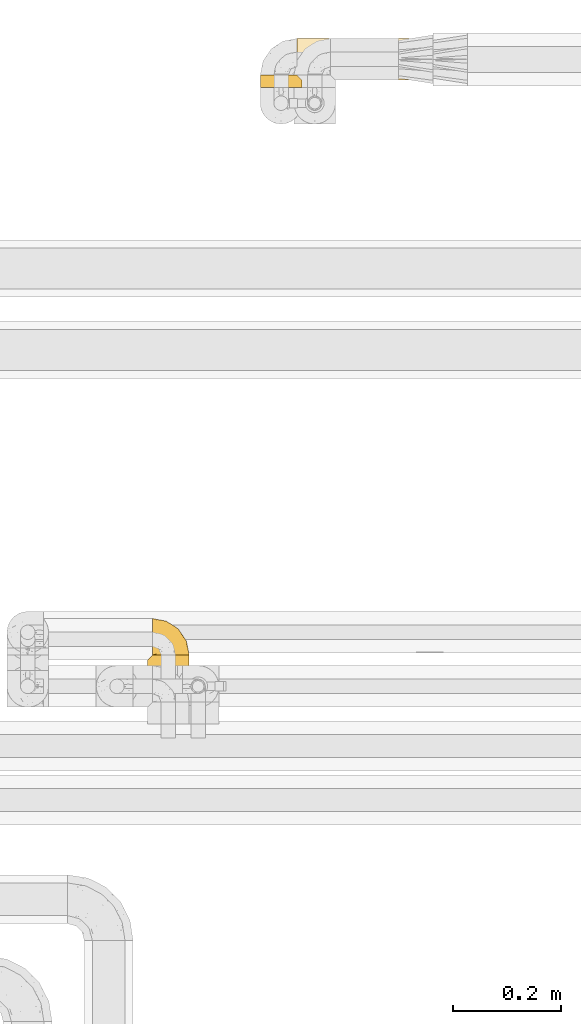
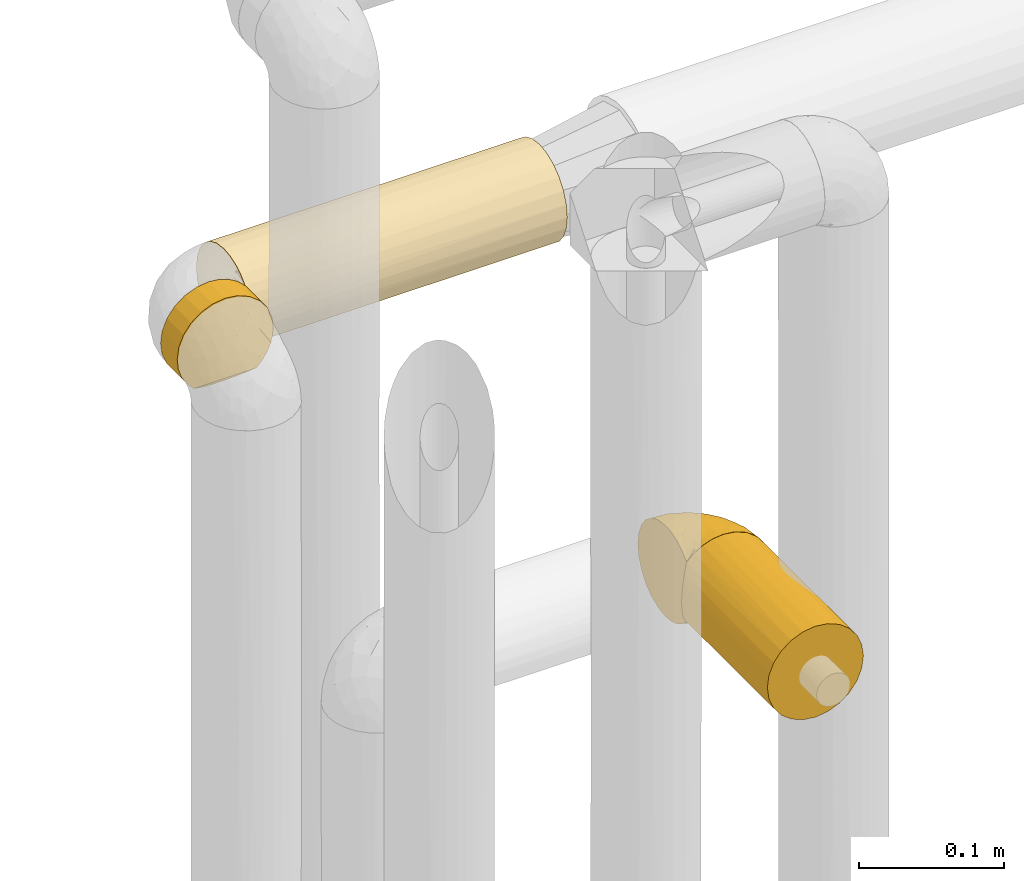
# One storey, part 332 of 827: 4 coverings.
"""IFC2X3 building model written with IfcOpenShell, lengths in millimetres."""

from ifc_helpers import new_model, entity, si_unit, converted_unit, derived_unit, direction, frame, origin, place, context, subcontext, project, spatial, faceted_brep, element, save


model = new_model("IFC2X3")

# Units and contexts
model_context = context("Model", 3, precision=0.01, world=origin(), true_north=direction((6.12303176911189e-17, 1.0)))
body_context = subcontext(model_context, "Body", "Model", "MODEL_VIEW")
ifc_project = project(units=[si_unit("LENGTHUNIT", "METRE", prefix="MILLI"), si_unit("AREAUNIT", "SQUARE_METRE"), si_unit("VOLUMEUNIT", "CUBIC_METRE"), converted_unit("PLANEANGLEUNIT", "DEGREE", entity("IfcRatioMeasure", 0.0174532925199433), si_unit("PLANEANGLEUNIT", "RADIAN"), dimensions=[0, 0, 0, 0, 0, 0, 0]), si_unit("MASSUNIT", "GRAM", prefix="KILO"), derived_unit("MASSDENSITYUNIT", [(si_unit("MASSUNIT", "GRAM", prefix="KILO"), 1), (si_unit("LENGTHUNIT", "METRE"), -3)]), derived_unit("MOMENTOFINERTIAUNIT", [(si_unit("LENGTHUNIT", "METRE"), 4)]), si_unit("TIMEUNIT", "SECOND"), si_unit("FREQUENCYUNIT", "HERTZ"), si_unit("THERMODYNAMICTEMPERATUREUNIT", "DEGREE_CELSIUS"), derived_unit("THERMALTRANSMITTANCEUNIT", [(si_unit("MASSUNIT", "GRAM", prefix="KILO"), 1), (si_unit("THERMODYNAMICTEMPERATUREUNIT", "KELVIN"), -1), (si_unit("TIMEUNIT", "SECOND"), -3)]), derived_unit("VOLUMETRICFLOWRATEUNIT", [(si_unit("LENGTHUNIT", "METRE"), 3), (si_unit("TIMEUNIT", "SECOND"), -1)]), derived_unit("MASSFLOWRATEUNIT", [(si_unit("MASSUNIT", "GRAM", prefix="KILO"), 1), (si_unit("TIMEUNIT", "SECOND"), -1)]), derived_unit("ROTATIONALFREQUENCYUNIT", [(si_unit("TIMEUNIT", "SECOND"), -1)]), si_unit("ELECTRICCURRENTUNIT", "AMPERE"), si_unit("ELECTRICVOLTAGEUNIT", "VOLT"), si_unit("POWERUNIT", "WATT"), si_unit("FORCEUNIT", "NEWTON", prefix="KILO"), si_unit("ILLUMINANCEUNIT", "LUX"), si_unit("LUMINOUSFLUXUNIT", "LUMEN"), si_unit("LUMINOUSINTENSITYUNIT", "CANDELA"), derived_unit("USERDEFINED", [(si_unit("MASSUNIT", "GRAM", prefix="KILO"), -1), (si_unit("LENGTHUNIT", "METRE"), -2), (si_unit("TIMEUNIT", "SECOND"), 3), (si_unit("LUMINOUSFLUXUNIT", "LUMEN"), 1)]), derived_unit("LINEARVELOCITYUNIT", [(si_unit("LENGTHUNIT", "METRE"), 1), (si_unit("TIMEUNIT", "SECOND"), -1)]), si_unit("PRESSUREUNIT", "PASCAL"), derived_unit("USERDEFINED", [(si_unit("LENGTHUNIT", "METRE"), -2), (si_unit("MASSUNIT", "GRAM", prefix="KILO"), 1), (si_unit("TIMEUNIT", "SECOND"), -2)]), derived_unit("LINEARFORCEUNIT", [(si_unit("MASSUNIT", "GRAM", prefix="KILO"), 1), (si_unit("LENGTHUNIT", "METRE"), 1), (si_unit("TIMEUNIT", "SECOND"), -2), (si_unit("LENGTHUNIT", "METRE"), -1)]), derived_unit("PLANARFORCEUNIT", [(si_unit("MASSUNIT", "GRAM", prefix="KILO"), 1), (si_unit("LENGTHUNIT", "METRE"), 1), (si_unit("TIMEUNIT", "SECOND"), -2), (si_unit("LENGTHUNIT", "METRE"), -2)])], contexts=[model_context])

# Site, building, storey
site_placement = place(None, origin())
site = spatial("IfcSite", under=ifc_project, at=site_placement, CompositionType="ELEMENT")
building_placement = place(site_placement, origin())
building = spatial("IfcBuilding", under=site, at=building_placement, CompositionType="ELEMENT")
storey_placement = place(building_placement, frame((0.0, 0.0, 28200.0)))
storey = spatial("IfcBuildingStorey", under=building, at=storey_placement, Name="08", CompositionType="ELEMENT", Elevation=28200.0)

# Coverings
covering_1_placement = place(storey_placement, frame((35021.28, 19454.61, 1660.0)))
element("IfcCovering", 1, at=covering_1_placement, inside=storey, Name=":ADSK_", ObjectType=":ADSK_", PredefinedType="INSULATION", context=body_context, shape_type="Brep", body=[
    faceted_brep([(253.75, 73.25, 20.8), (253.75, 77.09, 30.06), (253.75, 78.4, 40.0), (253.75, 77.09, 49.93), (253.75, 73.25, 59.2), (253.75, 67.15, 67.15), (253.75, 59.2, 73.25), (253.75, 49.93, 77.09), (253.75, 40.0, 78.4), (253.75, 30.06, 77.09), (253.75, 20.8, 73.25), (253.75, 12.84, 67.15), (253.75, 6.74, 59.2), (253.75, 2.9, 49.93), (253.75, 1.6, 40.0), (253.75, 2.9, 30.06), (253.75, 6.74, 20.8), (253.75, 12.84, 12.84), (253.75, 20.8, 6.74), (253.75, 30.06, 2.9), (253.75, 40.0, 1.6), (253.75, 49.93, 2.9), (253.75, 59.2, 6.74), (253.75, 67.15, 12.84), (1.6, 78.4, 40.0), (1.6, 77.09, 30.06), (1.6, 73.25, 20.8), (1.6, 67.15, 12.84), (1.6, 59.2, 6.74), (1.6, 49.93, 2.9), (1.6, 40.0, 1.6), (1.6, 31.79, 2.48), (1.6, 23.98, 5.09), (1.6, 16.91, 9.31), (1.6, 10.9, 14.94), (1.6, 10.9, 65.05), (1.6, 16.91, 70.68), (1.6, 23.98, 74.9), (1.6, 31.79, 77.51), (1.6, 40.0, 78.4), (1.6, 49.93, 77.09), (1.6, 59.2, 73.25), (1.6, 67.15, 67.15), (1.6, 73.25, 59.2), (1.6, 77.09, 49.93), (10.29, 2.2, 33.21), (8.5, 4.0, 26.63), (5.57, 6.92, 20.48), (10.9, 1.6, 40.0), (5.57, 6.92, 59.51), (8.5, 4.0, 53.36), (10.29, 2.2, 46.78)], [[[0, 1, 2, 3, 4, 5, 6, 7, 8, 9, 10, 11, 12, 13, 14, 15, 16, 17, 18, 19, 20, 21, 22, 23]], [[24, 25, 26, 27, 28, 29, 30, 31, 32, 33, 34, 35, 36, 37, 38, 39, 40, 41, 42, 43, 44]], [[45, 46, 15]], [[47, 34, 16]], [[46, 47, 16]], [[48, 45, 14]], [[14, 45, 15]], [[46, 16, 15]], [[34, 17, 16]], [[18, 33, 32]], [[19, 32, 31]], [[20, 31, 30]], [[17, 33, 18]], [[18, 32, 19]], [[31, 20, 19]], [[33, 17, 34]], [[21, 20, 30, 29]], [[22, 21, 29, 28]], [[28, 27, 23, 22]], [[1, 0, 26, 25]], [[2, 1, 25, 24]], [[27, 26, 0, 23]], [[3, 2, 24, 44]], [[4, 3, 44, 43]], [[43, 42, 5, 4]], [[7, 6, 41, 40]], [[8, 7, 40, 39]], [[42, 41, 6, 5]], [[8, 39, 38]], [[9, 38, 37]], [[10, 37, 36]], [[8, 38, 9]], [[9, 37, 10]], [[36, 11, 10]], [[36, 35, 11]], [[35, 49, 12]], [[50, 51, 13]], [[49, 50, 12]], [[12, 50, 13]], [[14, 13, 51]], [[48, 14, 51]], [[35, 12, 11]], [[34, 47, 46, 45, 48, 51, 50, 49, 35]]]),
])
covering_2_placement = place(storey_placement, frame((34953.78, 19440.94, 1660.0)))
element("IfcCovering", 2, at=covering_2_placement, inside=storey, Name=":ADSK_", ObjectType=":ADSK_", PredefinedType="INSULATION", context=body_context, shape_type="Brep", body=[
    faceted_brep([(20.8, 24.57, 73.25), (30.06, 24.57, 77.09), (40.0, 24.57, 78.4), (48.2, 24.57, 77.51), (56.01, 24.57, 74.9), (63.08, 24.57, 70.68), (69.1, 24.57, 65.05), (69.1, 24.57, 14.94), (63.08, 24.57, 9.31), (56.01, 24.57, 5.09), (48.2, 24.57, 2.48), (40.0, 24.57, 1.6), (30.06, 24.57, 2.9), (20.8, 24.57, 6.74), (12.84, 24.57, 12.84), (6.74, 24.57, 20.8), (2.9, 24.57, 30.06), (1.6, 24.57, 40.0), (2.9, 24.57, 49.93), (6.74, 24.57, 59.2), (12.84, 24.57, 67.15), (40.0, 1.6, 78.4), (30.06, 1.6, 77.09), (20.8, 1.6, 73.25), (12.84, 1.6, 67.15), (6.74, 1.6, 59.2), (2.9, 1.6, 49.93), (1.6, 1.6, 40.0), (2.48, 1.6, 31.79), (5.09, 1.6, 23.98), (9.31, 1.6, 16.91), (14.94, 1.6, 10.9), (65.05, 1.6, 10.9), (70.68, 1.6, 16.91), (74.9, 1.6, 23.98), (77.51, 1.6, 31.79), (78.4, 1.6, 40.0), (77.09, 1.6, 49.93), (73.25, 1.6, 59.2), (67.15, 1.6, 67.15), (59.2, 1.6, 73.25), (49.93, 1.6, 77.09), (77.79, 15.87, 33.21), (76.0, 17.67, 26.63), (73.07, 20.6, 20.48), (78.4, 15.27, 40.0), (59.51, 5.57, 6.92), (53.36, 8.5, 4.0), (46.78, 10.29, 2.2), (40.0, 10.9, 1.6), (33.21, 10.29, 2.2), (26.63, 8.5, 4.0), (20.48, 5.57, 6.92), (76.0, 17.67, 53.36), (77.79, 15.87, 46.78), (73.07, 20.6, 59.51)], [[[0, 1, 2, 3, 4, 5, 6, 7, 8, 9, 10, 11, 12, 13, 14, 15, 16, 17, 18, 19, 20]], [[21, 22, 23, 24, 25, 26, 27, 28, 29, 30, 31, 32, 33, 34, 35, 36, 37, 38, 39, 40, 41]], [[42, 36, 35]], [[35, 34, 43]], [[33, 44, 34]], [[42, 45, 36]], [[44, 43, 34]], [[7, 44, 33]], [[42, 35, 43]], [[33, 32, 7]], [[32, 46, 8]], [[47, 48, 10]], [[46, 47, 9]], [[8, 46, 9]], [[48, 11, 10]], [[10, 9, 47]], [[11, 48, 49]], [[32, 8, 7]], [[50, 51, 12]], [[13, 52, 14]], [[51, 52, 13]], [[49, 50, 11]], [[11, 50, 12]], [[51, 13, 12]], [[52, 31, 14]], [[15, 30, 29]], [[29, 28, 16]], [[27, 17, 28]], [[14, 30, 15]], [[16, 15, 29]], [[17, 16, 28]], [[30, 14, 31]], [[17, 27, 26, 18]], [[18, 26, 25, 19]], [[19, 25, 24, 20]], [[0, 23, 22, 1]], [[1, 22, 21, 2]], [[20, 24, 23, 0]], [[3, 21, 41]], [[41, 40, 4]], [[39, 5, 40]], [[2, 21, 3]], [[4, 3, 41]], [[5, 4, 40]], [[39, 6, 5]], [[53, 38, 37]], [[37, 36, 54]], [[45, 54, 36]], [[6, 39, 55]], [[54, 53, 37]], [[55, 38, 53]], [[55, 39, 38]], [[6, 55, 53, 54, 45, 42, 43, 44, 7]], [[52, 51, 50, 49, 48, 47, 46, 32, 31]]]),
])
covering_3_placement = place(storey_placement, frame((34745.39, 18264.91, 2170.0)))
element("IfcCovering", 3, at=covering_3_placement, inside=storey, Name=":ADSK_", ObjectType=":ADSK_", PredefinedType="INSULATION", context=body_context, shape_type="Brep", body=[
    faceted_brep([(30.06, 0.0, 2.9), (40.0, 0.0, 1.6), (49.93, 0.0, 2.9), (59.2, 0.0, 6.74), (67.15, 0.0, 12.84), (73.25, 0.0, 20.8), (77.09, 0.0, 30.06), (78.4, 0.0, 40.0), (77.09, 0.0, 49.93), (73.25, 0.0, 59.2), (67.15, 0.0, 67.15), (59.2, 0.0, 73.25), (49.93, 0.0, 77.09), (40.0, 0.0, 78.4), (30.06, 0.0, 77.09), (20.8, 0.0, 73.25), (12.84, 0.0, 67.15), (6.74, 0.0, 59.2), (2.9, 0.0, 49.93), (1.6, 0.0, 40.0), (2.9, 0.0, 30.06), (6.74, 0.0, 20.8), (12.84, 0.0, 12.84), (20.8, 0.0, 6.74), (40.0, 127.9, 1.6), (31.79, 127.9, 2.48), (23.98, 127.9, 5.09), (16.91, 127.9, 9.31), (10.9, 127.9, 14.94), (10.9, 127.9, 65.05), (16.91, 127.9, 70.68), (23.98, 127.9, 74.9), (31.79, 127.9, 77.51), (40.0, 127.9, 78.4), (49.93, 127.9, 77.09), (59.2, 127.9, 73.25), (67.15, 127.9, 67.15), (73.25, 127.9, 59.2), (77.09, 127.9, 49.93), (78.4, 127.9, 40.0), (77.09, 127.9, 30.06), (73.25, 127.9, 20.8), (67.15, 127.9, 12.84), (59.2, 127.9, 6.74), (49.93, 127.9, 2.9), (2.2, 119.2, 33.21), (4.0, 121.0, 26.63), (6.92, 123.92, 20.48), (1.6, 118.6, 40.0), (6.92, 123.92, 59.51), (4.0, 121.0, 53.36), (2.2, 119.2, 46.78)], [[[0, 1, 2, 3, 4, 5, 6, 7, 8, 9, 10, 11, 12, 13, 14, 15, 16, 17, 18, 19, 20, 21, 22, 23]], [[24, 25, 26, 27, 28, 29, 30, 31, 32, 33, 34, 35, 36, 37, 38, 39, 40, 41, 42, 43, 44]], [[45, 46, 20]], [[47, 28, 21]], [[46, 47, 21]], [[48, 45, 19]], [[19, 45, 20]], [[46, 21, 20]], [[28, 22, 21]], [[23, 27, 26]], [[0, 26, 25]], [[1, 25, 24]], [[22, 27, 23]], [[23, 26, 0]], [[25, 1, 0]], [[27, 22, 28]], [[2, 1, 24, 44]], [[3, 2, 44, 43]], [[43, 42, 4, 3]], [[6, 5, 41, 40]], [[7, 6, 40, 39]], [[42, 41, 5, 4]], [[8, 7, 39, 38]], [[9, 8, 38, 37]], [[37, 36, 10, 9]], [[12, 11, 35, 34]], [[13, 12, 34, 33]], [[36, 35, 11, 10]], [[13, 33, 32]], [[14, 32, 31]], [[15, 31, 30]], [[13, 32, 14]], [[14, 31, 15]], [[30, 16, 15]], [[30, 29, 16]], [[29, 49, 17]], [[50, 51, 18]], [[49, 50, 17]], [[17, 50, 18]], [[19, 18, 51]], [[48, 19, 51]], [[29, 17, 16]], [[48, 51, 50, 49, 29, 28, 47, 46, 45]]]),
])
covering_4_placement = place(storey_placement, frame((34754.69, 18391.21, 2169.95)))
element("IfcCovering", 4, at=covering_4_placement, inside=storey, Name=":ADSK_", ObjectType=":ADSK_", PredefinedType="INSULATION", context=body_context, shape_type="Brep", body=[
    faceted_brep([(47.38, 1.6, 5.41), (54.67, 1.6, 9.99), (60.76, 1.6, 16.08), (65.34, 1.6, 23.37), (68.18, 1.6, 31.49), (69.15, 1.6, 40.05), (68.18, 1.6, 48.61), (65.33, 1.6, 56.73), (60.75, 1.6, 64.02), (54.66, 1.6, 70.11), (47.37, 1.6, 74.69), (39.25, 1.6, 77.53), (30.7, 1.6, 78.5), (22.59, 1.6, 77.63), (14.86, 1.6, 75.08), (7.84, 1.6, 70.97), (1.85, 1.6, 65.47), (1.85, 1.6, 63.27), (1.85, 1.6, 61.53), (1.85, 1.6, 59.57), (1.85, 1.6, 57.6), (1.85, 1.6, 55.63), (1.85, 1.6, 53.67), (1.85, 1.6, 51.7), (1.85, 1.6, 49.73), (1.85, 1.6, 47.54), (1.85, 1.6, 45.34), (1.85, 1.6, 43.15), (1.85, 1.6, 40.96), (1.85, 1.6, 38.76), (1.85, 1.6, 36.57), (1.85, 1.6, 34.37), (1.85, 1.6, 32.18), (1.85, 1.6, 29.98), (1.85, 1.6, 27.79), (1.85, 1.6, 25.6), (1.85, 1.6, 23.4), (1.85, 1.6, 21.21), (1.85, 1.6, 19.01), (1.85, 1.6, 16.82), (1.85, 1.6, 14.62), (7.85, 1.6, 9.12), (14.88, 1.6, 5.0), (22.61, 1.6, 2.46), (30.7, 1.6, 1.6), (39.26, 1.6, 2.56), (1.6, 1.85, 65.47), (1.6, 7.85, 70.97), (1.6, 14.87, 75.09), (1.6, 22.6, 77.63), (1.6, 30.7, 78.5), (1.6, 40.65, 77.19), (1.6, 49.92, 73.34), (1.6, 57.88, 67.23), (1.6, 63.99, 59.27), (1.6, 67.84, 50.0), (1.6, 69.15, 40.05), (1.6, 67.84, 30.09), (1.6, 63.99, 20.82), (1.6, 57.88, 12.86), (1.6, 49.92, 6.75), (1.6, 40.65, 2.91), (1.6, 30.7, 1.6), (1.6, 22.6, 2.46), (1.6, 14.87, 5.0), (1.6, 7.85, 9.12), (1.6, 1.85, 14.62), (1.6, 1.85, 16.82), (1.6, 1.85, 17.8), (1.6, 1.85, 19.39), (1.6, 1.85, 20.98), (1.6, 1.85, 22.57), (1.6, 1.85, 24.16), (1.6, 1.85, 25.75), (1.6, 1.85, 27.33), (1.6, 1.85, 28.92), (1.6, 1.85, 30.51), (1.6, 1.85, 32.1), (1.6, 1.85, 33.69), (1.6, 1.85, 35.28), (1.6, 1.85, 36.87), (1.6, 1.85, 38.46), (1.6, 1.85, 40.05), (1.6, 1.85, 41.63), (1.6, 1.85, 43.22), (1.6, 1.85, 44.81), (1.6, 1.85, 46.4), (1.6, 1.85, 47.99), (1.6, 1.85, 49.58), (1.6, 1.85, 51.17), (1.6, 1.85, 52.76), (1.6, 1.85, 54.72), (1.6, 1.85, 56.69), (1.6, 1.85, 58.88), (1.6, 1.85, 61.08), (1.6, 1.85, 63.27), (1.78, 1.77, 37.77), (1.77, 1.78, 36.07), (1.78, 1.77, 32.96), (1.77, 1.77, 31.36), (1.79, 1.76, 56.52), (1.78, 1.77, 54.96), (1.76, 1.79, 18.75), (1.77, 1.78, 58.07), (1.77, 1.78, 50.37), (1.76, 1.78, 23.36), (1.77, 1.78, 24.95), (1.77, 1.78, 42.43), (1.8, 1.74, 15.97), (1.76, 1.78, 51.96), (1.77, 1.78, 53.47), (1.78, 1.77, 48.63), (1.77, 1.78, 63.93), (1.77, 1.78, 40.93), (1.76, 1.78, 29.72), (1.77, 1.77, 62.4), (1.78, 1.77, 60.92), (1.77, 1.77, 17.31), (1.77, 1.78, 21.74), (1.77, 1.78, 34.56), (1.78, 1.77, 20.18), (1.77, 1.77, 14.62), (1.8, 1.72, 14.62), (1.82, 1.66, 14.62), (1.77, 1.77, 65.47), (1.72, 1.8, 65.47), (1.66, 1.82, 65.47), (1.76, 1.79, 59.5), (1.77, 1.78, 47.1), (1.76, 1.79, 45.61), (1.77, 1.78, 28.18), (1.66, 1.82, 14.62), (1.72, 1.8, 14.62), (1.78, 1.76, 26.61), (1.82, 1.66, 65.47), (1.8, 1.72, 65.47), (1.77, 1.78, 39.32), (1.78, 1.77, 44.12), (3.72, 9.41, 72.26), (7.41, 17.65, 76.57), (6.13, 7.41, 71.77), (21.47, 21.47, 78.5), (19.34, 15.21, 77.9), (26.8, 16.15, 78.5), (8.87, 28.75, 78.5), (9.2, 13.67, 75.52), (12.79, 12.79, 76.13), (14.62, 19.18, 77.81), (5.33, 9.04, 72.4), (17.64, 7.41, 76.56), (7.7, 5.74, 71.77), (9.41, 3.72, 72.25), (28.75, 8.87, 78.5), (16.15, 26.8, 78.5), (14.14, 9.53, 75.75), (29.16, 7.34, 78.5), (9.2, 44.74, 75.57), (42.07, 12.03, 76.34), (11.99, 37.26, 77.64), (24.62, 56.57, 63.45), (15.19, 52.31, 70.55), (28.65, 45.87, 71.02), (53.59, 25.73, 66.15), (58.06, 26.34, 60.51), (50.57, 35.21, 63.72), (18.36, 42.07, 75.57), (46.98, 21.49, 72.61), (36.04, 22.52, 76.83), (50.24, 11.02, 72.61), (56.1, 15.64, 67.24), (21.34, 65.49, 47.19), (18.4, 63.99, 54.76), (12.07, 60.27, 63.45), (64.92, 17.92, 52.75), (40.1, 53.93, 53.89), (44.08, 53.36, 46.73), (33.21, 60.18, 48.67), (29.63, 59.54, 55.34), (49.36, 49.36, 40.05), (57.02, 37.63, 50.46), (64.0, 27.45, 40.05), (56.68, 38.4, 40.05), (28.97, 26.02, 77.74), (19.16, 34.22, 77.66), (54.46, 36.59, 57.43), (66.44, 15.2, 40.05), (62.12, 13.32, 60.51), (45.49, 45.25, 60.1), (49.27, 46.78, 51.88), (37.37, 35.9, 72.59), (29.39, 33.87, 76.05), (15.2, 66.44, 40.05), (35.57, 50.09, 63.95), (41.7, 41.08, 67.24), (46.4, 31.14, 69.62), (41.41, 28.19, 73.6), (27.45, 64.0, 40.05), (38.4, 56.68, 40.05), (21.33, 65.46, 32.72), (29.16, 7.34, 1.6), (42.08, 12.03, 3.75), (57.04, 37.61, 29.63), (42.89, 52.22, 27.18), (64.92, 17.91, 27.35), (58.07, 26.34, 19.59), (51.29, 28.05, 12.86), (56.11, 15.64, 12.86), (46.99, 21.48, 7.49), (21.89, 50.02, 9.54), (16.62, 59.28, 16.64), (32.9, 53.05, 17.48), (15.6, 35.39, 2.33), (16.15, 26.8, 1.6), (8.87, 28.75, 1.6), (32.83, 41.4, 8.17), (20.56, 40.48, 4.3), (13.16, 65.81, 26.94), (49.91, 41.02, 20.75), (10.83, 53.28, 9.54), (12.99, 43.9, 4.52), (50.25, 11.01, 7.49), (28.75, 8.87, 1.6), (26.8, 16.15, 1.6), (62.13, 13.31, 19.59), (36.04, 22.54, 3.27), (28.1, 27.68, 2.45), (21.47, 21.47, 1.6), (33.8, 59.8, 31.21), (25.02, 61.82, 25.33), (8.45, 37.3, 2.29), (41.73, 41.07, 12.86), (39.27, 32.24, 6.89), (21.46, 31.68, 2.23), (33.56, 47.4, 12.43), (27.29, 35.77, 4.1), (7.41, 17.65, 3.53), (3.51, 11.06, 6.88), (4.68, 8.55, 8.16), (5.52, 6.63, 9.02), (8.75, 12.77, 5.0), (12.79, 12.79, 3.96), (17.65, 7.41, 3.52), (13.9, 18.97, 2.4), (9.42, 3.72, 7.83), (7.68, 5.76, 8.32), (19.33, 15.21, 2.19), (14.13, 9.52, 4.34)], [[[0, 1, 2, 3, 4, 5, 6, 7, 8, 9, 10, 11, 12, 13, 14, 15, 16, 17, 18, 19, 20, 21, 22, 23, 24, 25, 26, 27, 28, 29, 30, 31, 32, 33, 34, 35, 36, 37, 38, 39, 40, 41, 42, 43, 44, 45]], [[46, 47, 48, 49, 50, 51, 52, 53, 54, 55, 56, 57, 58, 59, 60, 61, 62, 63, 64, 65, 66, 67, 68, 69, 70, 71, 72, 73, 74, 75, 76, 77, 78, 79, 80, 81, 82, 83, 84, 85, 86, 87, 88, 89, 90, 91, 92, 93, 94, 95]], [[96, 97, 30]], [[98, 77, 99]], [[100, 101, 21]], [[69, 68, 102]], [[20, 19, 103]], [[24, 23, 104]], [[20, 103, 100]], [[72, 105, 106]], [[84, 83, 107]], [[89, 88, 104]], [[108, 67, 66]], [[109, 110, 90]], [[111, 25, 24]], [[112, 17, 16]], [[82, 113, 83]], [[109, 23, 22]], [[114, 76, 75]], [[105, 36, 106]], [[104, 111, 24]], [[18, 115, 116]], [[97, 96, 80]], [[67, 108, 117]], [[105, 71, 118]], [[31, 97, 119]], [[102, 120, 69]], [[108, 121, 122, 123, 40]], [[112, 95, 115]], [[17, 115, 18]], [[94, 116, 115]], [[117, 68, 67]], [[38, 117, 39]], [[112, 124, 125, 126, 46]], [[17, 112, 115]], [[70, 120, 118]], [[39, 117, 108]], [[120, 38, 37]], [[120, 37, 118]], [[120, 70, 69]], [[116, 94, 127]], [[128, 86, 129]], [[117, 38, 102]], [[74, 130, 75]], [[99, 33, 32]], [[115, 95, 94]], [[39, 108, 40]], [[108, 66, 131, 132, 121]], [[105, 72, 71]], [[118, 37, 36]], [[71, 70, 118]], [[35, 106, 36]], [[36, 105, 118]], [[35, 133, 106]], [[74, 73, 133]], [[106, 133, 73]], [[99, 114, 33]], [[133, 35, 34]], [[73, 72, 106]], [[95, 112, 46]], [[112, 16, 134, 135, 124]], [[130, 114, 75]], [[99, 76, 114]], [[114, 130, 33]], [[34, 33, 130]], [[78, 77, 98]], [[98, 119, 78]], [[130, 133, 34]], [[133, 130, 74]], [[79, 97, 80]], [[98, 99, 32]], [[98, 32, 31]], [[77, 76, 99]], [[97, 79, 119]], [[136, 96, 29]], [[30, 97, 31]], [[136, 29, 28]], [[81, 80, 96]], [[29, 96, 30]], [[31, 119, 98]], [[119, 79, 78]], [[96, 136, 81]], [[82, 81, 136]], [[113, 107, 83]], [[84, 107, 137]], [[107, 27, 137]], [[113, 28, 107]], [[27, 107, 28]], [[85, 84, 137]], [[137, 27, 26]], [[113, 136, 28]], [[136, 113, 82]], [[109, 89, 104]], [[86, 85, 129]], [[89, 109, 90]], [[111, 87, 128]], [[26, 129, 137]], [[88, 111, 104]], [[25, 111, 128]], [[22, 110, 109]], [[23, 109, 104]], [[110, 91, 90]], [[100, 92, 101]], [[110, 22, 101]], [[91, 110, 101]], [[116, 19, 18]], [[111, 88, 87]], [[127, 103, 19]], [[25, 128, 26]], [[86, 128, 87]], [[128, 129, 26]], [[137, 129, 85]], [[120, 102, 38]], [[117, 102, 68]], [[91, 101, 92]], [[21, 101, 22]], [[93, 92, 103]], [[100, 21, 20]], [[100, 103, 92]], [[127, 93, 103]], [[93, 127, 94]], [[116, 127, 19]], [[126, 138, 47]], [[48, 138, 139]], [[140, 125, 124]], [[141, 142, 143]], [[144, 49, 139]], [[145, 140, 146]], [[48, 139, 49]], [[139, 145, 147]], [[144, 50, 49]], [[126, 125, 148]], [[14, 13, 149]], [[150, 146, 140]], [[148, 140, 145]], [[151, 150, 135]], [[151, 14, 149]], [[16, 15, 134]], [[13, 152, 149]], [[124, 150, 140]], [[141, 147, 142]], [[14, 151, 15]], [[15, 151, 134]], [[47, 46, 126]], [[139, 153, 144]], [[138, 48, 47]], [[125, 140, 148]], [[135, 134, 151]], [[146, 154, 142]], [[145, 146, 147]], [[148, 139, 138]], [[147, 141, 153]], [[147, 146, 142]], [[139, 147, 153]], [[139, 148, 145]], [[148, 138, 126]], [[154, 146, 150]], [[149, 143, 142]], [[151, 154, 150]], [[149, 142, 154]], [[13, 12, 155, 152]], [[152, 143, 149]], [[151, 149, 154]], [[150, 124, 135]], [[51, 156, 52]], [[155, 11, 157]], [[50, 144, 158]], [[159, 160, 161]], [[162, 163, 164]], [[158, 165, 156]], [[157, 166, 167]], [[166, 168, 169]], [[170, 55, 171]], [[161, 160, 165]], [[172, 54, 53]], [[160, 53, 52]], [[173, 7, 6]], [[54, 172, 171]], [[174, 175, 176]], [[170, 177, 176]], [[167, 143, 157]], [[178, 179, 180, 181]], [[157, 11, 10]], [[141, 182, 183]], [[160, 52, 156]], [[173, 179, 184]], [[8, 169, 9]], [[173, 6, 185]], [[155, 12, 11]], [[8, 7, 186]], [[162, 169, 163]], [[187, 184, 188]], [[180, 173, 185]], [[10, 168, 157]], [[54, 171, 55]], [[186, 173, 163]], [[157, 143, 152, 155]], [[189, 161, 190]], [[179, 173, 180]], [[9, 168, 10]], [[186, 169, 8]], [[187, 164, 184]], [[144, 183, 158]], [[172, 160, 159]], [[177, 174, 176]], [[55, 170, 191]], [[187, 192, 193]], [[183, 182, 190]], [[166, 194, 195]], [[167, 190, 182]], [[6, 5, 185]], [[173, 186, 7]], [[169, 186, 163]], [[169, 168, 9]], [[157, 168, 166]], [[190, 161, 165]], [[161, 193, 192]], [[183, 165, 158]], [[194, 189, 195]], [[191, 170, 196]], [[191, 56, 55]], [[175, 178, 197]], [[197, 196, 176]], [[170, 176, 196]], [[188, 175, 174]], [[197, 176, 175]], [[177, 170, 171]], [[171, 159, 177]], [[192, 177, 159]], [[187, 188, 174]], [[188, 179, 178]], [[174, 177, 192]], [[164, 187, 193]], [[174, 192, 187]], [[161, 192, 159]], [[194, 164, 193]], [[184, 164, 163]], [[189, 194, 193]], [[162, 166, 169]], [[161, 189, 193]], [[195, 190, 167]], [[173, 184, 163]], [[184, 179, 188]], [[164, 194, 162]], [[166, 162, 194]], [[190, 195, 189]], [[167, 182, 143]], [[167, 166, 195]], [[160, 172, 53]], [[171, 172, 159]], [[51, 50, 158]], [[160, 156, 165]], [[51, 158, 156]], [[183, 144, 153]], [[141, 183, 153]], [[190, 165, 183]], [[178, 175, 188]], [[143, 182, 141]], [[198, 191, 196]], [[45, 199, 200]], [[178, 201, 202]], [[201, 203, 204]], [[205, 206, 207]], [[57, 56, 191]], [[4, 185, 5]], [[208, 209, 210]], [[211, 212, 213]], [[208, 214, 215]], [[216, 209, 58]], [[201, 217, 202]], [[59, 218, 60]], [[60, 218, 219]], [[201, 178, 181, 180]], [[1, 0, 220]], [[201, 180, 203]], [[200, 199, 221, 222]], [[203, 185, 4]], [[3, 203, 4]], [[2, 1, 206]], [[217, 210, 202]], [[58, 209, 59]], [[3, 223, 203]], [[207, 220, 200]], [[204, 223, 206]], [[205, 204, 206]], [[207, 200, 224]], [[200, 222, 224]], [[206, 223, 2]], [[225, 222, 226]], [[220, 206, 1]], [[60, 219, 61]], [[57, 198, 216]], [[227, 202, 228]], [[3, 2, 223]], [[45, 44, 199]], [[0, 45, 200]], [[219, 211, 229]], [[230, 231, 214]], [[231, 207, 224]], [[210, 209, 228]], [[218, 209, 208]], [[226, 232, 225]], [[231, 230, 205]], [[202, 210, 228]], [[233, 230, 214]], [[227, 228, 198]], [[201, 204, 217]], [[211, 232, 212]], [[180, 185, 203]], [[61, 229, 62]], [[203, 223, 204]], [[200, 220, 0]], [[206, 220, 207]], [[225, 231, 224]], [[232, 226, 212]], [[214, 231, 234]], [[197, 227, 196]], [[191, 198, 57]], [[198, 228, 216]], [[202, 197, 178]], [[196, 227, 198]], [[197, 202, 227]], [[209, 216, 228]], [[58, 57, 216]], [[229, 211, 213]], [[215, 211, 219]], [[205, 217, 204]], [[210, 217, 230]], [[62, 229, 213]], [[219, 229, 61]], [[231, 205, 207]], [[217, 205, 230]], [[215, 214, 234]], [[233, 208, 210]], [[209, 218, 59]], [[219, 218, 208]], [[208, 215, 219]], [[232, 215, 234]], [[215, 232, 211]], [[232, 234, 225]], [[231, 225, 234]], [[222, 225, 224]], [[208, 233, 214]], [[210, 230, 233]], [[63, 213, 235]], [[213, 212, 235]], [[213, 63, 62]], [[236, 235, 237]], [[237, 132, 131]], [[235, 236, 64]], [[238, 239, 240]], [[63, 235, 64]], [[131, 66, 65]], [[236, 131, 65]], [[241, 221, 43]], [[236, 65, 64]], [[238, 121, 132]], [[42, 241, 43]], [[240, 239, 242]], [[41, 123, 243]], [[43, 221, 199, 44]], [[243, 122, 244]], [[226, 245, 242]], [[240, 246, 244]], [[121, 238, 244]], [[41, 40, 123]], [[132, 237, 238]], [[243, 42, 41]], [[131, 236, 237]], [[239, 238, 237]], [[244, 238, 240]], [[246, 240, 245]], [[246, 243, 244]], [[237, 235, 239]], [[242, 235, 212]], [[235, 242, 239]], [[226, 222, 245]], [[242, 212, 226]], [[241, 245, 222]], [[242, 245, 240]], [[245, 241, 246]], [[243, 246, 241]], [[241, 222, 221]], [[42, 243, 241]], [[122, 243, 123]], [[122, 121, 244]]]),
])

save(model, "model.ifc")
